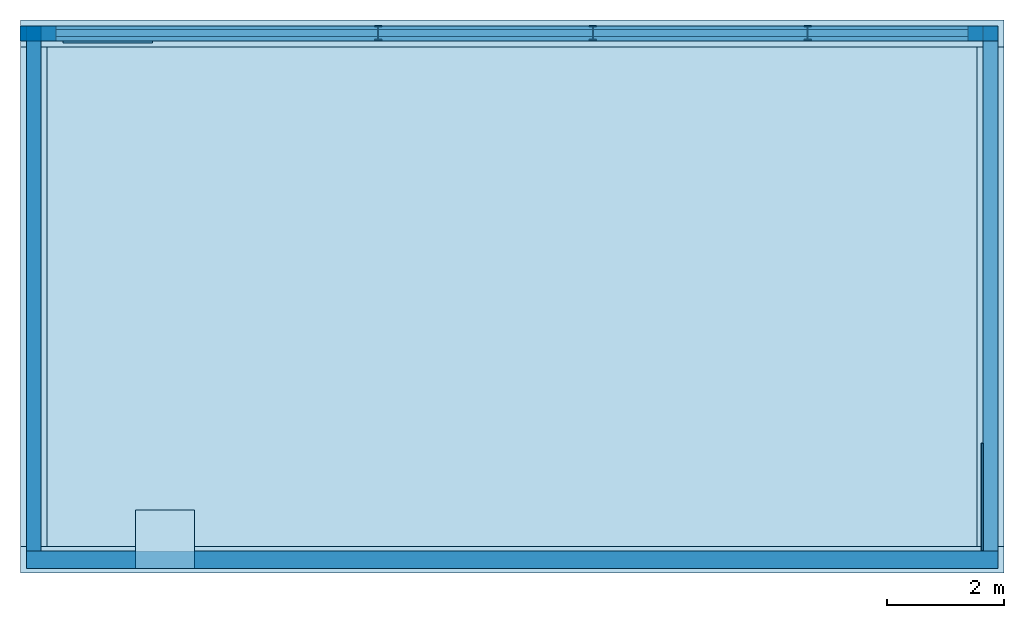
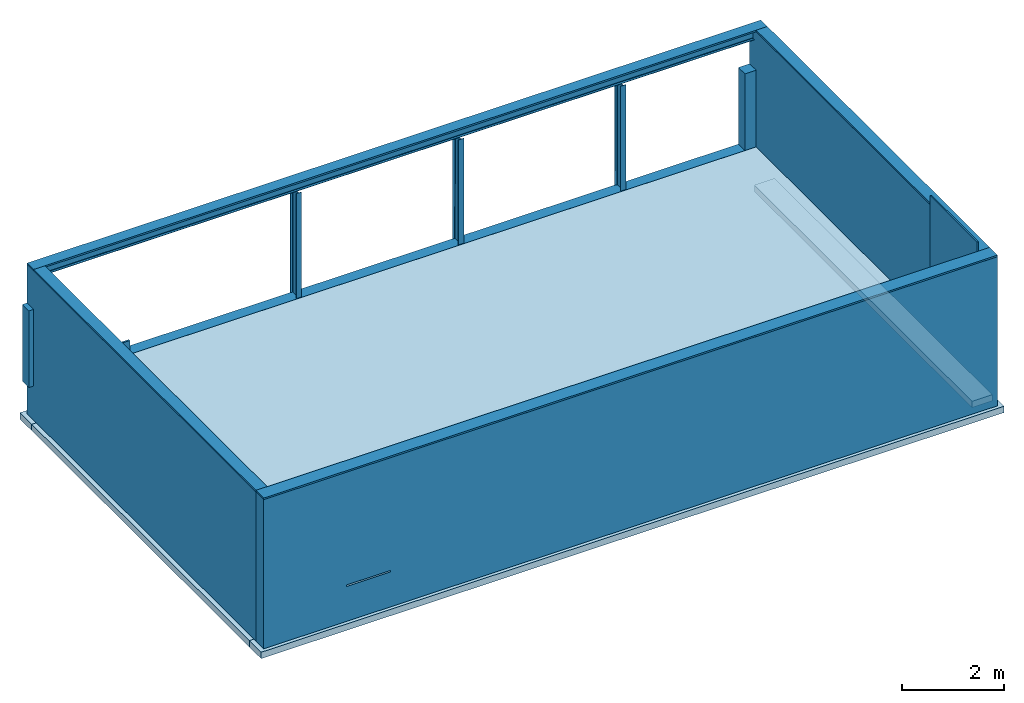
# One storey: 6 walls, 5 beams, 5 members, 4 footings, 1 plate, 1 slab.
"""IFC4 building model written with IfcOpenShell, lengths in inches."""

import ifcopenshell
import ifcopenshell.guid

model = None  # the IFC model being written
_history = None  # IfcOwnerHistory: only IFC2X3 demands one
_inside = {}  # id of a spatial element -> (the spatial element, [elements in it])
_under = {}  # id of a project, library or spatial element -> (it, [spatial elements below it])
_declared = {}  # id of a project -> (the project, [libraries it declares])
_typed = {}  # id of a type object -> (the type object, [elements of that type])
_made_of = {}  # id of a material, layer set ... -> (it, [elements and type objects made of it])


def new_model(schema):
    """Start an empty IFC model of exactly this schema.

    Asked for "IFC4X3", IfcOpenShell would pick the latest addendum, in which some entities
    have other attributes; the version numbers below select the first issue.
    IFC2X3 requires an IfcOwnerHistory on every rooted entity: one is made here for all.
    """
    global model, _history
    if schema == "IFC4X3":
        model = ifcopenshell.file(schema_version=(4, 3, 0, 0))
    else:
        model = ifcopenshell.file(schema=schema)
    _inside.clear()
    _under.clear()
    _declared.clear()
    _typed.clear()
    _made_of.clear()
    _history = None
    if model.schema == "IFC2X3":
        org = make("IfcOrganization", Name="unknown")
        user = make(
            "IfcPersonAndOrganization",
            ThePerson=make("IfcPerson", FamilyName="unknown"),
            TheOrganization=org,
        )
        app = make(
            "IfcApplication",
            ApplicationDeveloper=org,
            Version="unknown",
            ApplicationFullName="unknown",
            ApplicationIdentifier="unknown",
        )
        _history = make(
            "IfcOwnerHistory",
            OwningUser=user,
            OwningApplication=app,
            ChangeAction="ADDED",
            CreationDate=0,
        )
    return model


def make(cls, **values):
    """One entity of the class cls with the attributes given. An attribute that is None is left unset."""
    return model.create_entity(
        cls, **{name: value for name, value in values.items() if value is not None}
    )


def entity(cls, *values):
    """Any entity or typed value of the class cls, its attributes in the order of the schema. None: left unset."""
    e = model.create_entity(cls)
    for i, value in enumerate(values):
        if value is not None:
            e[i] = value
    return e


def rooted(cls, **values):
    """An entity with a GlobalId (a new one), such as an element, a storey or a relation."""
    return make(cls, GlobalId=ifcopenshell.guid.new(), OwnerHistory=_history, **values)


def si_unit(unit_type, name, prefix=None):
    """IfcSIUnit, for example si_unit("LENGTHUNIT", "METRE", prefix="MILLI")."""
    return make("IfcSIUnit", UnitType=unit_type, Prefix=prefix, Name=name)


def converted_unit(unit_type, name, factor, base, dimensions=None, offset=None):
    """IfcConversionBasedUnit, such as the inch: factor (a typed value) times the base unit."""
    return make(
        "IfcConversionBasedUnit"
        if offset is None
        else "IfcConversionBasedUnitWithOffset",
        ConversionOffset=offset,
        Dimensions=None
        if dimensions is None
        else entity("IfcDimensionalExponents", *dimensions),
        UnitType=unit_type,
        Name=name,
        ConversionFactor=make(
            "IfcMeasureWithUnit", ValueComponent=factor, UnitComponent=base
        ),
    )


def assignment(units):
    """IfcUnitAssignment: the units of a project."""
    return None if units is None else make("IfcUnitAssignment", Units=units)


def point(xyz):
    """IfcCartesianPoint."""
    return None if xyz is None else make("IfcCartesianPoint", Coordinates=xyz)


def direction(xyz):
    """IfcDirection."""
    return None if xyz is None else make("IfcDirection", DirectionRatios=xyz)


def frame(location, z_axis=None, x_axis=None):
    """IfcAxis2Placement3D, a coordinate frame: its origin and axes. An axis left out is left unset."""
    return make(
        "IfcAxis2Placement3D",
        Location=point(location),
        Axis=direction(z_axis),
        RefDirection=direction(x_axis),
    )


def frame_2d(location, x_axis=None):
    """IfcAxis2Placement2D, a coordinate frame in the plane: its origin and x axis."""
    return make(
        "IfcAxis2Placement2D", Location=point(location), RefDirection=direction(x_axis)
    )


def origin_with_axes():
    """The frame at (0, 0, 0) with the z axis (0, 0, 1) and the x axis (1, 0, 0) written out."""
    return frame((0.0, 0.0, 0.0), z_axis=(0.0, 0.0, 1.0), x_axis=(1.0, 0.0, 0.0))


def origin_2d_with_axis():
    """The frame at (0, 0) in the plane with the x axis (1, 0) written out."""
    return frame_2d((0.0, 0.0), x_axis=(1.0, 0.0))


def place(relative_to, where):
    """IfcLocalPlacement: puts the frame where relative to a parent placement (None: the world)."""
    return make(
        "IfcLocalPlacement", PlacementRelTo=relative_to, RelativePlacement=where
    )


def context(
    kind, dimensions, precision=None, world=None, true_north=None, identifier=None
):
    """IfcGeometricRepresentationContext, for example the 3D "Model" context."""
    return make(
        "IfcGeometricRepresentationContext",
        ContextIdentifier=identifier,
        ContextType=kind,
        CoordinateSpaceDimension=dimensions,
        Precision=precision,
        WorldCoordinateSystem=world,
        TrueNorth=true_north,
    )


def subcontext(parent, identifier, kind, view, scale=None):
    """IfcGeometricRepresentationSubContext, for example "Body" below "Model"."""
    return make(
        "IfcGeometricRepresentationSubContext",
        ContextIdentifier=identifier,
        ContextType=kind,
        ParentContext=parent,
        TargetScale=scale,
        TargetView=view,
    )


def project(units=None, contexts=None):
    """IfcProject with its units and contexts."""
    return rooted(
        "IfcProject",
        Name="project",
        RepresentationContexts=contexts,
        UnitsInContext=assignment(units),
    )


def spatial(cls, under=None, at=None, **own):
    """A site, building, storey or space (cls), placed at a placement, below another one or the project."""
    s = rooted(cls, ObjectPlacement=at, **own)
    if under is not None:
        _under.setdefault(under.id(), (under, []))[1].append(s)
    return s


def point_list(points):
    """IfcCartesianPointList2D or 3D."""
    cls = (
        "IfcCartesianPointList2D" if len(points[0]) == 2 else "IfcCartesianPointList3D"
    )
    return make(cls, CoordList=points)


def line(*indices):
    """IfcLineIndex: a straight run through numbered points of an indexed curve."""
    return model.create_entity("IfcLineIndex", indices)


def indexed_curve(points, segments=None, self_intersect=None):
    """IfcIndexedPolyCurve: lines and arcs through numbered points (the first is 1)."""
    return make(
        "IfcIndexedPolyCurve",
        Points=point_list(points),
        Segments=segments,
        SelfIntersect=self_intersect,
    )


def profile(cls, at=None, kind="AREA", **sizes):
    """A parametric profile (cls). Its sizes go by their IFC names, for example OverallWidth=200.0."""
    return make(cls, ProfileType=kind, Position=at, **sizes)


def i_section(**sizes):
    """IfcIShapeProfileDef."""
    return profile("IfcIShapeProfileDef", **sizes)


def outline(outer, holes=None, kind="AREA"):
    """IfcArbitraryClosedProfileDef: a profile drawn as a closed curve; with holes, ...WithVoids."""
    if holes is None:
        return make("IfcArbitraryClosedProfileDef", ProfileType=kind, OuterCurve=outer)
    return make(
        "IfcArbitraryProfileDefWithVoids",
        ProfileType=kind,
        OuterCurve=outer,
        InnerCurves=holes,
    )


def extrude(swept, where, along, depth):
    """IfcExtrudedAreaSolid: the profile swept, set in the frame where, extruded along a direction by depth."""
    return make(
        "IfcExtrudedAreaSolid",
        SweptArea=swept,
        Position=where,
        ExtrudedDirection=direction(along),
        Depth=depth,
    )


def shape(context_of_items, identifier, shape_type, items):
    """IfcShapeRepresentation: the items that make up one representation, for example the "Body"."""
    return make(
        "IfcShapeRepresentation",
        ContextOfItems=context_of_items,
        RepresentationIdentifier=identifier,
        RepresentationType=shape_type,
        Items=items,
    )


def material(Name=None, Category=None):
    """IfcMaterial."""
    return make("IfcMaterial", Name=Name, Category=Category)


def layer(
    of_material, thickness, ventilated=None, Name=None, Category=None, Priority=None
):
    """IfcMaterialLayer: one layer of a wall or slab, of a material (None: an air gap)."""
    return make(
        "IfcMaterialLayer",
        Material=of_material,
        LayerThickness=thickness,
        IsVentilated=ventilated,
        Name=Name,
        Category=Category,
        Priority=Priority,
    )


def layer_set(layers, Name=None):
    """IfcMaterialLayerSet."""
    return make("IfcMaterialLayerSet", MaterialLayers=layers, LayerSetName=Name)


def layer_usage(for_layer_set, set_direction, sense, offset, extent=None):
    """IfcMaterialLayerSetUsage: how a layer set lies in its element."""
    return make(
        "IfcMaterialLayerSetUsage",
        ForLayerSet=for_layer_set,
        LayerSetDirection=set_direction,
        DirectionSense=sense,
        OffsetFromReferenceLine=offset,
        ReferenceExtent=extent,
    )


def material_profile(
    of_material, cross_section, Name=None, Category=None, Priority=None
):
    """IfcMaterialProfile: a cross section and its material."""
    return make(
        "IfcMaterialProfile",
        Name=Name,
        Material=of_material,
        Profile=cross_section,
        Priority=Priority,
        Category=Category,
    )


def profile_set(profiles, Name=None, composite=None):
    """IfcMaterialProfileSet."""
    return make(
        "IfcMaterialProfileSet",
        Name=Name,
        MaterialProfiles=profiles,
        CompositeProfile=composite,
    )


def profile_usage(for_profile_set, cardinal=None, extent=None):
    """IfcMaterialProfileSetUsage: how a profile set lies along its element."""
    return make(
        "IfcMaterialProfileSetUsage",
        ForProfileSet=for_profile_set,
        CardinalPoint=cardinal,
        ReferenceExtent=extent,
    )


def made_of(thing, what):
    """Note that an element or type object is made of a material, layer set ...; save() writes the relation."""
    if what is not None:
        _made_of.setdefault(what.id(), (what, []))[1].append(thing)
    return thing


def type_object(cls, material=None, **own):
    """A type object (cls), such as IfcWallType, which elements share."""
    return made_of(rooted(cls, **own), material)


def element(
    cls,
    number,
    at=None,
    inside=None,
    cuts=None,
    type_object=None,
    material=None,
    context=None,
    identifier="Body",
    shape_type=None,
    held_by="IfcProductDefinitionShape",
    body=None,
    shapes=None,
    **own,
):
    """One element of the class cls, such as IfcWall. Its Tag is "e" and its number.

    at: its placement. inside: the storey or other place that contains it. cuts: it is an
    opening in that element (IfcRelVoidsElement). A single representation is given by context,
    identifier, shape_type and body (its items); several are given by shapes. held_by: the class
    of the entity that holds the representations. save() writes the other relations.
    """
    e = rooted(cls, Tag="e%d" % number, ObjectPlacement=at, **own)
    if body is not None:
        shapes = [shape(context, identifier, shape_type, body)]
    if shapes is not None:
        e.Representation = make(held_by, Representations=shapes)
    if inside is not None:
        _inside.setdefault(inside.id(), (inside, []))[1].append(e)
    if cuts is not None:
        rooted(
            "IfcRelVoidsElement", RelatingBuildingElement=cuts, RelatedOpeningElement=e
        )
    if type_object is not None:
        _typed.setdefault(type_object.id(), (type_object, []))[1].append(e)
    return made_of(e, material)


def aggregate(whole, parts):
    """IfcRelAggregates: a whole, such as a stair, and the parts it consists of."""
    return rooted("IfcRelAggregates", RelatingObject=whole, RelatedObjects=parts)


def save(model, path):
    """Write the relations noted so far, then the file.

    IfcRelAggregates (storeys below a building ...), IfcRelContainedInSpatialStructure (elements
    in a storey), IfcRelDefinesByType, IfcRelAssociatesMaterial and IfcRelDeclares: one each for
    every whole, place, type object, material and project.
    """
    for whole, parts in _under.values():
        aggregate(whole, parts)
    for where, things in _inside.values():
        rooted(
            "IfcRelContainedInSpatialStructure",
            RelatedElements=things,
            RelatingStructure=where,
        )
    for kind, things in _typed.values():
        rooted("IfcRelDefinesByType", RelatedObjects=things, RelatingType=kind)
    for what, things in _made_of.values():
        rooted("IfcRelAssociatesMaterial", RelatedObjects=things, RelatingMaterial=what)
    for by, libraries in _declared.values():
        rooted("IfcRelDeclares", RelatingContext=by, RelatedDefinitions=libraries)
    model.write(path)


model = new_model("IFC4")

# Units and contexts
model_context = context("Model", 3, precision=1e-05, world=origin_with_axes())
plan_context = context("Plan", 2, precision=1e-05, world=origin_2d_with_axis())
body_context = subcontext(model_context, "Body", "Model", "MODEL_VIEW")
ifc_project = project(units=[converted_unit("PLANEANGLEUNIT", "degree", entity("IfcReal", 0.0174532925199433), si_unit("PLANEANGLEUNIT", "RADIAN"), dimensions=[0, 0, 0, 0, 0, 0, 0]), converted_unit("AREAUNIT", "square inch", entity("IfcReal", 0.0006452), si_unit("AREAUNIT", "SQUARE_METRE"), dimensions=[2, 0, 0, 0, 0, 0, 0]), converted_unit("LENGTHUNIT", "inch", entity("IfcReal", 0.0254), si_unit("LENGTHUNIT", "METRE"), dimensions=[1, 0, 0, 0, 0, 0, 0]), converted_unit("VOLUMEUNIT", "cubic inch", entity("IfcReal", 1.639e-05), si_unit("VOLUMEUNIT", "CUBIC_METRE"), dimensions=[3, 0, 0, 0, 0, 0, 0])], contexts=[model_context, plan_context])

# Site, building, storey
site_placement = place(None, origin_with_axes())
site = spatial("IfcSite", under=ifc_project, at=site_placement)
building_placement = place(site_placement, frame((0.0, 0.0, 109.012492998378), z_axis=(0.0, 0.0, 1.0), x_axis=(1.0, 0.0, 0.0)))
building = spatial("IfcBuilding", under=site, at=building_placement, Name="Building")
storey_placement = place(building_placement, frame((0.0, 0.0, -247.012489423977), z_axis=(0.0, 0.0, 1.0), x_axis=(1.0, 0.0, 0.0)))
storey = spatial("IfcBuildingStorey", under=building, at=storey_placement, Name="Basement")

# Footings
ifc_material_1 = material(Name="Default")
ifc_layer_1 = layer(ifc_material_1, 18.0, Name="18in concrete")
ifc_layer_set_1 = layer_set([ifc_layer_1], Name="18in concrete")
ifc_layer_usage_1 = layer_usage(ifc_layer_set_1, "AXIS2", "POSITIVE", 0.0)
footing_type = type_object("IfcFootingType", Name="18in", PredefinedType="STRIP_FOOTING", material=ifc_layer_set_1)
footing_1_placement = place(storey_placement, frame((637.000226599025, 9.99999797250342, -40.2187550161763), z_axis=(0.0, 0.0, 1.0), x_axis=(-1.0, 6.27832946520357e-07, 0.0)))
element("IfcFooting", 1, at=footing_1_placement, inside=storey, type_object=footing_type, material=ifc_layer_usage_1, Name="Footing", PredefinedType="NOTDEFINED", context=body_context, shape_type="SweptSolid", body=[
    extrude(outline(indexed_curve([(0.0, 0.0), (0.0, 18.0), (659.500247386021, 18.0), (659.500247386021, 0.0), (0.0, 0.0)], self_intersect=False)), origin_with_axes(), (0.0, 0.0, 1.0), 6.0),
])
ifc_layer_usage_2 = layer_usage(ifc_layer_set_1, "AXIS2", "POSITIVE", 0.0)
footing_2_placement = place(storey_placement, frame((637.000076414093, -342.878919886792, -40.2187550161763), z_axis=(0.0, 0.0, 1.0), x_axis=(-1.0, 6.27832946520357e-07, 0.0)))
element("IfcFooting", 2, at=footing_2_placement, inside=storey, type_object=footing_type, material=ifc_layer_usage_2, Name="Footing", PredefinedType="NOTDEFINED", context=body_context, shape_type="SweptSolid", body=[
    extrude(outline(indexed_curve([(0.0, 0.0), (0.0, 18.0), (659.500319110539, 18.0), (659.500319110539, 0.0), (0.0, 0.0)], self_intersect=False)), origin_with_axes(), (0.0, 0.0, 1.0), 6.0),
])
ifc_layer_usage_3 = layer_usage(ifc_layer_set_1, "AXIS2", "POSITIVE", 0.0)
footing_3_placement = place(storey_placement, frame((637.000076414093, -342.878994979258, -40.2187550161763), z_axis=(0.0, 0.0, 1.0), x_axis=(5.52335052361741e-07, 1.0, 0.0)))
element("IfcFooting", 3, at=footing_3_placement, inside=storey, type_object=footing_type, material=ifc_layer_usage_3, Name="Footing", PredefinedType="NOTDEFINED", context=body_context, shape_type="SweptSolid", body=[
    extrude(outline(indexed_curve([(0.0, 0.0), (0.0, 18.0), (334.878975347916, 18.0), (334.878975347916, 0.0), (0.0, 0.0)], self_intersect=False)), origin_with_axes(), (0.0, 0.0, 1.0), 6.0),
])
ifc_layer_usage_4 = layer_usage(ifc_layer_set_1, "AXIS2", "POSITIVE", 0.0)
footing_4_placement = place(storey_placement, frame((-4.50022225304851, -342.878957433025, -40.2187550161763), z_axis=(0.0, 0.0, 1.0), x_axis=(5.52335052361741e-07, 1.0, 0.0)))
element("IfcFooting", 4, at=footing_4_placement, inside=storey, type_object=footing_type, material=ifc_layer_usage_4, Name="Footing", PredefinedType="NOTDEFINED", context=body_context, shape_type="SweptSolid", body=[
    extrude(outline(indexed_curve([(0.0, 0.0), (0.0, 18.0), (334.878975347916, 18.0), (334.878975347916, 0.0), (0.0, 0.0)], self_intersect=False)), origin_with_axes(), (0.0, 0.0, 1.0), 6.0),
])

# Beams
ifc_layer_2 = layer(ifc_material_1, 1.25, Name="1.25in rim joist")
ifc_layer_set_2 = layer_set([ifc_layer_2], Name="1.25in rim joist")
ifc_layer_usage_5 = layer_usage(ifc_layer_set_2, "AXIS2", "POSITIVE", 0.0)
beam_type_1 = type_object("IfcBeamType", Name="1.25in rim joist", PredefinedType="JOIST", material=ifc_layer_set_2)
beam_1_placement = place(storey_placement, frame((623.000099903017, -345.878901444082, 3.32192716029574e-13), z_axis=(0.0, 0.0, 1.0), x_axis=(5.52335052361741e-07, 1.0, 0.0)))
element("IfcBeam", 5, at=beam_1_placement, inside=storey, type_object=beam_type_1, material=ifc_layer_usage_5, Name="Beam", PredefinedType="NOTDEFINED", context=body_context, shape_type="SweptSolid", body=[
    extrude(outline(indexed_curve([(0.0, 0.0), (0.0, 1.25), (72.0, 1.25), (72.0, 0.0), (0.0, 0.0)], self_intersect=False)), origin_with_axes(), (0.0, 0.0, 1.0), 116.0),
])
ifc_material_2 = material()
ifc_material_profile = material_profile(ifc_material_2, i_section(OverallWidth=4.7244094488189, OverallDepth=9.44881889763779, WebThickness=0.244094488188976, FlangeThickness=0.385826771653543, FilletRadius=0.590551181102362))
ifc_profile_set = profile_set([ifc_material_profile])
ifc_profile_usage_1 = profile_usage(ifc_profile_set, cardinal=11)
beam_type_2 = type_object("IfcBeamType", Name="IPE240", PredefinedType="NOTDEFINED", material=ifc_profile_set)
beam_2_placement = place(storey_placement, frame((623.000212541715, 1.27561713062872, 101.060275956402), z_axis=(-1.0, 2.82129946072018e-07, -1.62920684942947e-07), x_axis=(-2.82129974493728e-07, -1.0, 1.19209275339927e-07)))
element("IfcBeam", 6, at=beam_2_placement, inside=storey, type_object=beam_type_2, material=ifc_profile_usage_1, Name="Beam", PredefinedType="NOTDEFINED", context=body_context, shape_type="SweptSolid", body=[
    extrude(i_section(OverallWidth=4.7244094488189, OverallDepth=9.44881889763779, WebThickness=0.244094488188976, FlangeThickness=0.385826771653543, FilletRadius=0.590551181102362), origin_with_axes(), (0.0, 0.0, 1.0), 631.500315016628),
])
ifc_profile_usage_2 = profile_usage(ifc_profile_set, cardinal=11)
beam_3_placement = place(storey_placement, frame((217.362182346855, 1.27569339641436, -3.3273002294101), z_axis=(-3.15952178198131e-07, -0.000736867019440979, 0.999999701976776), x_axis=(1.0, -2.9406276098598e-06, 3.13785420757995e-07)))
element("IfcBeam", 7, at=beam_3_placement, inside=storey, type_object=beam_type_2, material=ifc_profile_usage_2, Name="Beam", PredefinedType="NOTDEFINED", context=body_context, shape_type="SweptSolid", body=[
    extrude(i_section(OverallWidth=4.7244094488189, OverallDepth=9.44881889763779, WebThickness=0.244094488188976, FlangeThickness=0.385826771653543, FilletRadius=0.590551181102362), origin_with_axes(), (0.0, 0.0, 1.0), 99.6630960359357),
])
ifc_profile_usage_3 = profile_usage(ifc_profile_set, cardinal=11)
beam_4_placement = place(storey_placement, frame((361.362179433267, 1.27569339641436, -3.3273002294101), z_axis=(-3.15952178198131e-07, -0.000736867019440979, 0.999999701976776), x_axis=(1.0, -2.9406276098598e-06, 3.13785420757995e-07)))
element("IfcBeam", 8, at=beam_4_placement, inside=storey, type_object=beam_type_2, material=ifc_profile_usage_3, Name="Beam", PredefinedType="NOTDEFINED", context=body_context, shape_type="SweptSolid", body=[
    extrude(i_section(OverallWidth=4.7244094488189, OverallDepth=9.44881889763779, WebThickness=0.244094488188976, FlangeThickness=0.385826771653543, FilletRadius=0.590551181102362), origin_with_axes(), (0.0, 0.0, 1.0), 99.6630960359357),
])
ifc_profile_usage_4 = profile_usage(ifc_profile_set, cardinal=11)
beam_5_placement = place(storey_placement, frame((505.362195292796, 1.27569339641436, -3.3273002294101), z_axis=(-3.15952178198131e-07, -0.000736867019440979, 0.999999701976776), x_axis=(1.0, -2.9406276098598e-06, 3.13785420757995e-07)))
element("IfcBeam", 9, at=beam_5_placement, inside=storey, type_object=beam_type_2, material=ifc_profile_usage_4, Name="Beam", PredefinedType="NOTDEFINED", context=body_context, shape_type="SweptSolid", body=[
    extrude(i_section(OverallWidth=4.7244094488189, OverallDepth=9.44881889763779, WebThickness=0.244094488188976, FlangeThickness=0.385826771653543, FilletRadius=0.590551181102362), origin_with_axes(), (0.0, 0.0, 1.0), 99.6630960359357),
])

# Members
ifc_layer_3 = layer(ifc_material_1, 1.5, Name="2x10 wood member")
ifc_layer_set_3 = layer_set([ifc_layer_3], Name="2x10 wood member")
ifc_layer_usage_6 = layer_usage(ifc_layer_set_3, "AXIS2", "POSITIVE", 0.0)
member_type_1 = type_object("IfcMemberType", Name="2x10 wood member plate", PredefinedType="PLATE", material=ifc_layer_set_3)
member_1_placement = place(storey_placement, frame((-18.5001224983396, -3.99996915201503, 107.281245584563), z_axis=(1.00386177506479e-14, 1.0, -7.43468717701035e-06), x_axis=(1.0, 4.42138036252371e-12, 5.96046447753906e-07)))
element("IfcMember", 10, at=member_1_placement, inside=storey, type_object=member_type_1, material=ifc_layer_usage_6, Name="Member", PredefinedType="NOTDEFINED", context=body_context, shape_type="SweptSolid", body=[
    extrude(outline(indexed_curve([(0.0, 0.0), (0.0, 1.5), (651.500346371661, 1.5), (651.500346371661, 0.0), (0.0, 0.0)], self_intersect=False)), origin_with_axes(), (0.0, 0.0, 1.0), 10.0),
])
ifc_layer_usage_7 = layer_usage(ifc_layer_set_3, "AXIS2", "POSITIVE", 0.0)
member_2_placement = place(storey_placement, frame((5.98699558438279, -5.54894133815615, 3.84644197507928e-13), z_axis=(0.0, 0.0, 1.0), x_axis=(1.0, 0.0, 0.0)))
element("IfcMember", 11, at=member_2_placement, inside=storey, type_object=member_type_1, material=ifc_layer_usage_7, Name="Member", PredefinedType="NOTDEFINED", context=body_context, shape_type="SweptSolid", body=[
    extrude(outline(indexed_curve([(0.0, 0.0), (0.0, 1.5), (60.0, 1.5), (60.0, 0.0), (0.0, 0.0)], self_intersect=False)), origin_with_axes(), (0.0, 0.0, 1.0), 12.0),
])
ifc_layer_usage_8 = layer_usage(ifc_layer_set_3, "AXIS2", "POSITIVE", 0.0)
member_3_placement = place(storey_placement, frame((-18.5001213250198, -3.99998088521282, 107.284580159375), z_axis=(1.0, -4.37114131557337e-08, -4.37113882867379e-08), x_axis=(-4.37113882867379e-08, -1.0, 5.06639537434239e-07)))
element("IfcMember", 12, at=member_3_placement, inside=storey, type_object=member_type_1, material=ifc_layer_usage_8, Name="Member", PredefinedType="NOTDEFINED", context=body_context, shape_type="SweptSolid", body=[
    extrude(outline(indexed_curve([(0.0, 0.0), (0.0, 1.5), (341.878612320965, 1.5), (341.878612320965, 0.0), (0.0, 0.0)], self_intersect=False)), origin_with_axes(), (0.0, 0.0, 1.0), 10.0),
])
ifc_layer_usage_9 = layer_usage(ifc_layer_set_3, "AXIS2", "POSITIVE", 0.0)
member_4_placement = place(storey_placement, frame((623.000212541715, -3.99998088521282, 107.284580159375), z_axis=(1.0, -4.37114131557337e-08, -4.37113882867379e-08), x_axis=(-4.37113882867379e-08, -1.0, 5.06639537434239e-07)))
element("IfcMember", 13, at=member_4_placement, inside=storey, type_object=member_type_1, material=ifc_layer_usage_9, Name="Member", PredefinedType="NOTDEFINED", context=body_context, shape_type="SweptSolid", body=[
    extrude(outline(indexed_curve([(0.0, 0.0), (0.0, 1.5), (341.878612320965, 1.5), (341.878612320965, 0.0), (0.0, 0.0)], self_intersect=False)), origin_with_axes(), (0.0, 0.0, 1.0), 10.0),
])
ifc_layer_4 = layer(ifc_material_1, 1.5, Name="2x12 wood member plate")
ifc_layer_set_4 = layer_set([ifc_layer_4], Name="2x12 wood member plate")
ifc_layer_usage_10 = layer_usage(ifc_layer_set_4, "AXIS2", "POSITIVE", 0.0)
member_type_2 = type_object("IfcMemberType", Name="2x12 wood member plate", PredefinedType="PLATE", material=ifc_layer_set_4)
member_5_placement = place(storey_placement, frame((-18.5002304437592, -357.878602395846, 107.281236198005), z_axis=(1.00386177506479e-14, 1.0, -7.43468717701035e-06), x_axis=(1.0, 4.42138036252371e-12, 5.96046447753906e-07)))
element("IfcMember", 14, at=member_5_placement, inside=storey, type_object=member_type_2, material=ifc_layer_usage_10, Name="Member", PredefinedType="NOTDEFINED", context=body_context, shape_type="SweptSolid", body=[
    extrude(outline(indexed_curve([(0.0, 0.0), (0.0, 1.5), (651.500346371661, 1.5), (651.500346371661, 0.0), (0.0, 0.0)], self_intersect=False)), origin_with_axes(), (0.0, 0.0, 1.0), 12.0),
])

# Slab
ifc_layer_5 = layer(ifc_material_1, 8.0, Name="8in concrete slab")
ifc_layer_set_5 = layer_set([ifc_layer_5], Name="8in concrete slab")
ifc_layer_usage_11 = layer_usage(ifc_layer_set_5, "AXIS3", "POSITIVE", 0.0)
slab_type = type_object("IfcSlabType", Name="8in concrete slab", PredefinedType="BASESLAB", material=ifc_layer_set_5)
slab_placement = place(storey_placement, frame((-8.50028585730575, -345.878601074219, -10.2187423255496), z_axis=(0.0, 0.0, 1.0), x_axis=(1.0, 0.0, 0.0)))
element("IfcSlab", 15, at=slab_placement, inside=storey, type_object=slab_type, material=ifc_layer_usage_11, Name="Slab", PredefinedType="NOTDEFINED", context=body_context, shape_type="SweptSolid", body=[
    extrude(outline(indexed_curve([(0.0, 0.0), (631.500379307064, 0.0), (631.500379307064, 341.878613149087), (0.0, 341.878613149087)], segments=[line(3, 2), line(2, 1), line(1, 4), line(4, 3)], self_intersect=False)), None, (0.0, 0.0, 1.0), 8.0),
])

# Plate
plate_placement = place(storey_placement, frame((54.8633487205806, -357.878639942079, -1.50000016520309), z_axis=(0.0, 0.0, 1.0), x_axis=(1.0, 0.0, 0.0)))
element("IfcPlate", 16, at=plate_placement, inside=storey, Name="Plate", PredefinedType="NOTDEFINED", context=body_context, shape_type="SweptSolid", body=[
    extrude(outline(indexed_curve([(0.0, 0.0), (39.3700787401575, 0.0), (39.3700787401575, 39.3700787401575), (0.0, 39.3700787401575), (0.0, 0.0)])), None, (0.0, 0.0, 1.0), 1.5),
])

# Walls
ifc_layer_6 = layer(ifc_material_1, 10.0, Name="10 in concrete wall")
ifc_layer_set_6 = layer_set([ifc_layer_6], Name="10 in concrete wall")
ifc_layer_usage_12 = layer_usage(ifc_layer_set_6, "AXIS2", "POSITIVE", 0.0)
wall_type_1 = type_object("IfcWallType", Name="10 in Concrete Wall", PredefinedType="SOLIDWALL", material=ifc_layer_set_6)
wall_1_placement = place(storey_placement, frame((-18.5001224983396, 6.00001943393016, -34.2187543553626), z_axis=(0.0, 0.0, 1.0), x_axis=(-2.82129974493728e-07, -1.0, 0.0)))
element("IfcWall", 17, at=wall_1_placement, inside=storey, type_object=wall_type_1, material=ifc_layer_usage_12, Name="Wall", PredefinedType="NOTDEFINED", context=body_context, shape_type="SweptSolid", body=[
    extrude(outline(indexed_curve([(0.0, 0.0), (0.0, 10.0), (351.878631825617, 10.0), (351.878631825617, 0.0), (0.0, 0.0)], self_intersect=False)), origin_with_axes(), (0.0, 0.0, 1.0), 140.0),
])
ifc_layer_usage_13 = layer_usage(ifc_layer_set_6, "AXIS2", "POSITIVE", 0.0)
wall_2_placement = place(storey_placement, frame((623.000212541715, 6.00001943393016, -34.2187543553626), z_axis=(0.0, 0.0, 1.0), x_axis=(-2.82129974493728e-07, -1.0, 0.0)))
element("IfcWall", 18, at=wall_2_placement, inside=storey, type_object=wall_type_1, material=ifc_layer_usage_13, Name="Wall", PredefinedType="NOTDEFINED", context=body_context, shape_type="SweptSolid", body=[
    extrude(outline(indexed_curve([(0.0, 0.0), (0.0, 10.0), (351.878934288491, 10.0), (351.878934288491, 0.0), (0.0, 0.0)], self_intersect=False)), origin_with_axes(), (0.0, 0.0, 1.0), 140.0),
])
ifc_layer_usage_14 = layer_usage(ifc_layer_set_6, "AXIS2", "POSITIVE", 0.0)
wall_3_placement = place(storey_placement, frame((623.000024810551, 6.00001650063072, -2.21874770217016), z_axis=(0.0, 0.0, 1.0), x_axis=(-1.0, 1.50995802528087e-07, 0.0)))
element("IfcWall", 19, at=wall_3_placement, inside=storey, type_object=wall_type_1, material=ifc_layer_usage_14, Name="Wall", PredefinedType="NOTDEFINED", context=body_context, shape_type="SweptSolid", body=[
    extrude(outline(indexed_curve([(0.0, 0.0), (0.0, 10.0), (9.99998848641903, 10.0), (9.99998848641903, 0.0), (0.0, 0.0)], self_intersect=False)), origin_with_axes(), (0.0, 0.0, 1.0), 72.0),
])
ifc_layer_usage_15 = layer_usage(ifc_layer_set_6, "AXIS2", "POSITIVE", 0.0)
wall_4_placement = place(storey_placement, frame((1.49984411367281, 6.00001650063072, -2.21875708872839), z_axis=(0.0, 0.0, 1.0), x_axis=(-1.0, 1.50995802528087e-07, 0.0)))
element("IfcWall", 20, at=wall_4_placement, inside=storey, type_object=wall_type_1, material=ifc_layer_usage_15, Name="Wall", PredefinedType="NOTDEFINED", context=body_context, shape_type="SweptSolid", body=[
    extrude(outline(indexed_curve([(0.0, 0.0), (0.0, 10.0), (24.2043808893006, 10.0), (24.2043808893006, 0.0), (0.0, 0.0)], self_intersect=False)), origin_with_axes(), (0.0, 0.0, 1.0), 72.0),
])
ifc_layer_usage_16 = layer_usage(ifc_layer_set_6, "AXIS2", "POSITIVE", 0.0)
wall_5_placement = place(storey_placement, frame((623.000174995482, 6.00001826061039, -34.2187543553626), z_axis=(0.0, 0.0, 1.0), x_axis=(-1.0, 1.50995802528087e-07, 0.0)))
element("IfcWall", 21, at=wall_5_placement, inside=storey, type_object=wall_type_1, material=ifc_layer_usage_16, Name="Wall", PredefinedType="NOTDEFINED", context=body_context, shape_type="SweptSolid", body=[
    extrude(outline(indexed_curve([(0.0, 0.0), (0.0, 10.0), (631.500315016601, 10.0), (631.500315016601, 0.0), (0.0, 0.0)], self_intersect=False)), origin_with_axes(), (0.0, 0.0, 1.0), 32.0),
])
ifc_layer_7 = layer(ifc_material_1, 12.0, Name="12 in concrete wall")
ifc_layer_set_7 = layer_set([ifc_layer_7], Name="12 in concrete wall")
ifc_layer_usage_17 = layer_usage(ifc_layer_set_7, "AXIS2", "POSITIVE", 0.0)
wall_type_2 = type_object("IfcWallType", Name="12 in concrete wall", PredefinedType="SOLIDWALL", material=ifc_layer_set_7)
wall_6_placement = place(storey_placement, frame((-18.5002280971197, -357.878602395846, -34.2187543553626), z_axis=(0.0, 0.0, 1.0), x_axis=(1.0, -4.76837158203125e-07, 0.0)))
element("IfcWall", 22, at=wall_6_placement, inside=storey, type_object=wall_type_2, material=ifc_layer_usage_17, Name="Wall", PredefinedType="NOTDEFINED", context=body_context, shape_type="SweptSolid", body=[
    extrude(outline(indexed_curve([(0.0, 0.0), (0.0, 12.0), (651.500273766484, 12.0), (651.500273766484, 0.0), (0.0, 0.0)], self_intersect=False)), origin_with_axes(), (0.0, 0.0, 1.0), 140.0),
])

save(model, "model.ifc")
